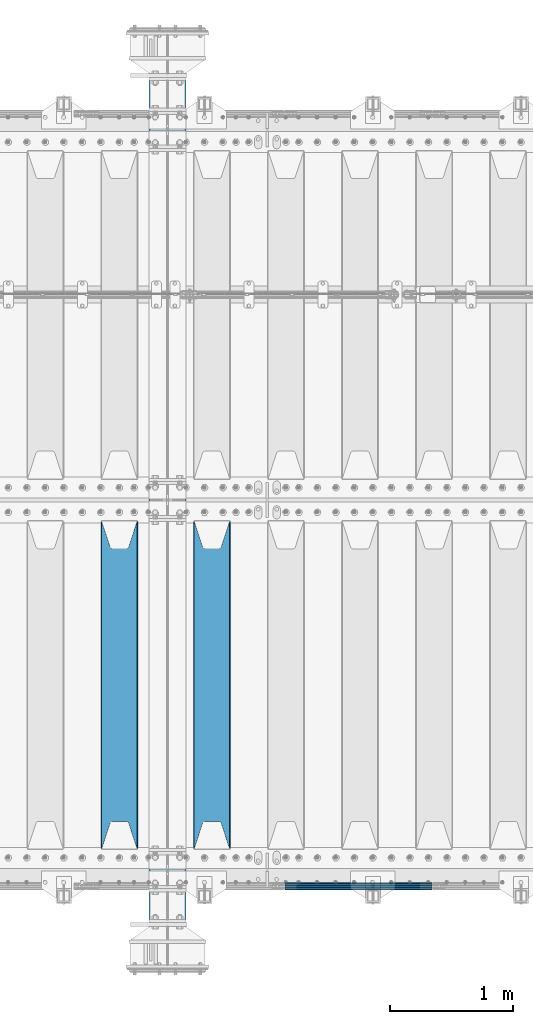
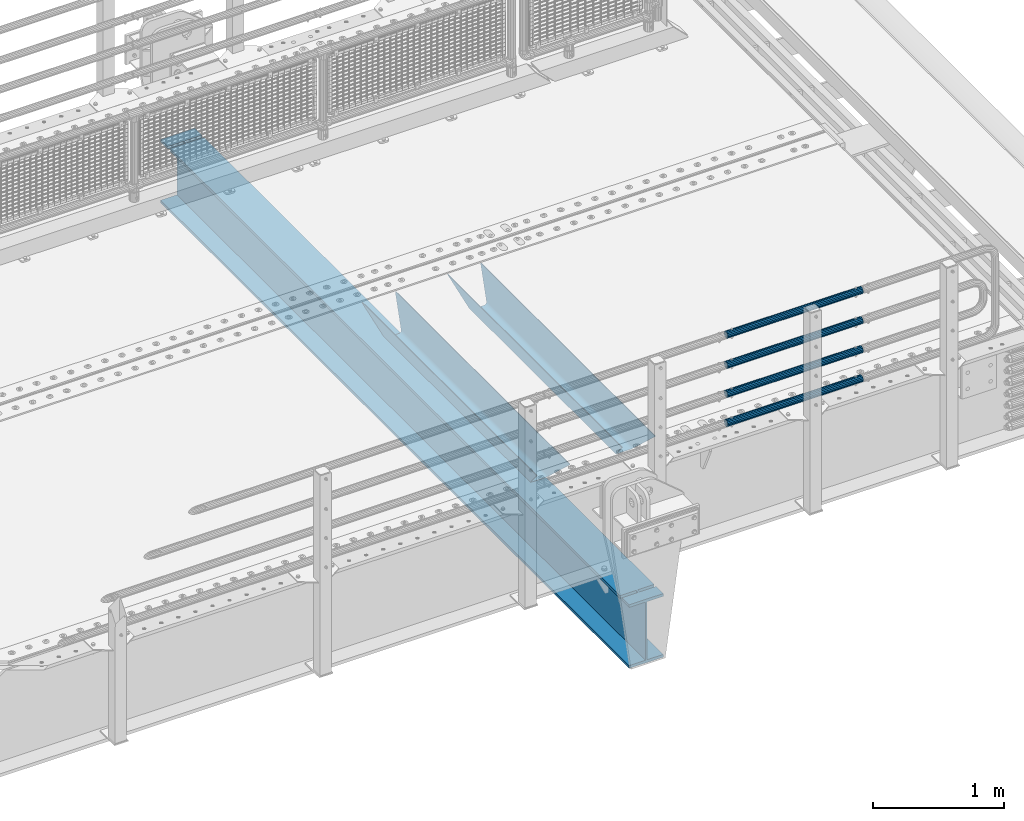
# One storey, part 95 of 193: 7 beams.
"""IFC2X3 building model written with IfcOpenShell, lengths in millimetres."""

from ifc_helpers import new_model, si_unit, frame, origin_with_axes, place, context, subcontext, project, spatial, faceted_brep, material, type_object, element, save


model = new_model("IFC2X3")

# Units and contexts
model_context = context("Model", 3, precision=1e-05, world=origin_with_axes())
body_context = subcontext(model_context, "Body", "Model", "MODEL_VIEW")
ifc_project = project(units=[si_unit("LENGTHUNIT", "METRE", prefix="MILLI"), si_unit("AREAUNIT", "SQUARE_METRE"), si_unit("VOLUMEUNIT", "CUBIC_METRE"), si_unit("MASSUNIT", "GRAM", prefix="KILO"), si_unit("TIMEUNIT", "SECOND"), si_unit("PLANEANGLEUNIT", "RADIAN"), si_unit("SOLIDANGLEUNIT", "STERADIAN"), si_unit("THERMODYNAMICTEMPERATUREUNIT", "DEGREE_CELSIUS"), si_unit("LUMINOUSINTENSITYUNIT", "LUMEN")], contexts=[model_context])

# Site, building, storey
site_placement = place(None, origin_with_axes())
site = spatial("IfcSite", under=ifc_project, at=site_placement, CompositionType="ELEMENT")
building_placement = place(site_placement, origin_with_axes())
building = spatial("IfcBuilding", under=site, at=building_placement, Name="Standard", CompositionType="ELEMENT")
storey_placement = place(building_placement, origin_with_axes())
storey = spatial("IfcBuildingStorey", under=building, at=storey_placement, Name="Undefined", CompositionType="ELEMENT", Elevation=0.0)

# Beams
ifc_material_1 = material(Name="STEEL/S355N")
beam_type_1 = type_object("IfcBeamType", PredefinedType="NOTDEFINED")
beam_1_placement = place(storey_placement, frame((-31700.0, 24175.0, -115.0), z_axis=(0.0, 0.0, 1.0), x_axis=(0.0, 1.0, 0.0)))
element("IfcBeam", 1, at=beam_1_placement, inside=storey, type_object=beam_type_1, material=ifc_material_1, context=body_context, shape_type="Brep", body=[
    faceted_brep([(0.0, 150.0, 115.0), (0.0, 143.689999999999, 115.0), (2650.00000000297, 143.689999999999, 115.0), (2650.00000000297, 150.0, 115.0), (2650.00000000297, 142.059565218398, 110.000000003094), (2650.00000000297, 148.3695652184, 110.000000003094), (2441.90079219209, -80.1103600731112, -98.0992078077845), (2437.7588105432, -77.5672621345584, -102.241189456673), (2434.06523489747, -74.4080125315522, -105.934765102404), (2430.9108609509, -70.710272125576, -109.089139048974), (2428.37322971128, -66.5649389910068, -111.626770288588), (2426.51472138055, -62.0739139532889, -113.485278619323), (2425.38102192092, -57.3475956567672, -114.618978078955), (2424.99999999988, -52.5021667386536, -115.0), (2424.99999999988, 52.5021667386536, -115.0), (2425.38102192092, 57.3475956567672, -114.618978078955), (2426.51472138055, 62.0739139532889, -113.485278619323), (2428.37322971128, 66.5649389910068, -111.626770288588), (2430.9108609509, 70.710272125576, -109.089139048974), (2434.06523489747, 74.4080125315522, -105.934765102404), (2437.7588105432, 77.5672621345584, -102.241189456673), (2441.90079219209, 80.1103600731112, -98.0992078077846), (2446.38936140512, 81.9747917625791, -93.6106385947584), (2448.2494850041, 76.2713538057251, -91.7505149957729), (2444.62967112263, 74.76777986261, -95.3703288772456), (2441.28936334127, 72.7168944282894, -98.710636658607), (2438.31067330439, 70.1691124903846, -101.689326695487), (2435.76682334748, 67.1870637758839, -104.233176652398), (2433.72034654134, 63.8440531834895, -106.279653458539), (2432.22154950042, 60.222258798236, -107.778450499454), (2431.30727574265, 56.4107117849089, -108.692724257221), (2430.99999999987, 52.5031078186876, -109.0), (2430.99999999987, -52.5031078186876, -109.0), (2431.30727574265, -56.4107117849089, -108.692724257221), (2432.22154950042, -60.222258798236, -107.778450499454), (2433.72034654134, -63.8440531834895, -106.279653458539), (2435.76682334748, -67.1870637758839, -104.233176652398), (2438.31067330439, -70.1691124903846, -101.689326695487), (2441.28936334127, -72.7168944282894, -98.7106366586071), (2444.62967112263, -74.76777986261, -95.3703288772457), (2448.2494850041, -76.2713538057251, -91.7505149957729), (2650.00000000297, -142.059565218398, 110.000000003094), (2650.00000000297, -148.3695652184, 110.000000003094), (2446.38936140512, -81.9747917625791, -93.6106385947584), (2650.00000000297, -143.689999999999, 115.0), (2650.00000000297, -150.0, 115.0), (0.0, -143.689999999999, 115.0), (0.0, -150.0, 115.0), (0.0, -148.369565218261, 110.000000002667), (203.610638597427, -81.9747917625791, -93.6106385947584), (208.099207810446, -80.1103600731112, -98.0992078077845), (212.241189459342, -77.5672621345584, -102.241189456673), (215.93476510507, -74.4080125315522, -105.934765102404), (219.089139051641, -70.710272125576, -109.089139048974), (221.626770291256, -66.5649389910068, -111.626770288588), (223.485278621989, -62.0739139532889, -113.485278619323), (224.618978081624, -57.3475956567672, -114.618978078955), (225.000000002663, -52.5021667386536, -115.0), (225.000000002663, 52.5021667386536, -115.0), (224.618978081624, 57.3475956567672, -114.618978078955), (223.485278621989, 62.0739139532889, -113.485278619323), (221.626770291256, 66.5649389910068, -111.626770288588), (219.089139051641, 70.710272125576, -109.089139048974), (215.93476510507, 74.4080125315522, -105.934765102404), (212.241189459342, 77.5672621345584, -102.241189456673), (208.099207810446, 80.1103600731112, -98.0992078077846), (203.610638597427, 81.9747917625791, -93.6106385947584), (0.0, 148.369565218261, 110.000000002667), (0.0, 142.05956521826, 110.000000002667), (201.750514998439, 76.2713538057251, -91.7505149957729), (205.370328879915, 74.76777986261, -95.3703288772456), (208.710636661275, 72.7168944282894, -98.710636658607), (211.689326698157, 70.1691124903846, -101.689326695487), (214.233176655063, 67.1870637758839, -104.233176652398), (216.279653461206, 63.8440531834895, -106.279653458539), (217.778450502123, 60.222258798236, -107.778450499454), (218.69272425989, 56.4107117849089, -108.692724257221), (219.00000000267, 52.5031078186876, -109.0), (219.00000000267, -52.5031078186876, -109.0), (218.69272425989, -56.4107117849089, -108.692724257221), (217.778450502123, -60.222258798236, -107.778450499454), (216.279653461206, -63.8440531834895, -106.279653458539), (214.233176655063, -67.1870637758839, -104.233176652398), (211.689326698157, -70.1691124903846, -101.689326695487), (208.710636661275, -72.7168944282894, -98.7106366586071), (205.370328879915, -74.76777986261, -95.3703288772457), (201.750514998439, -76.2713538057251, -91.7505149957729), (0.0, -142.05956521826, 110.000000002667)], [[[0, 1, 2, 3]], [[3, 2, 4, 5]], [[6, 7, 8, 9, 10, 11, 12, 13, 14, 15, 16, 17, 18, 19, 20, 21, 22, 5, 4, 23, 24, 25, 26, 27, 28, 29, 30, 31, 32, 33, 34, 35, 36, 37, 38, 39, 40, 41, 42, 43]], [[44, 45, 42, 41]], [[46, 47, 45, 44]], [[43, 42, 45, 47, 48, 49]], [[6, 43, 49, 50]], [[7, 6, 50, 51]], [[8, 7, 51, 52]], [[9, 8, 52, 53]], [[10, 9, 53, 54]], [[11, 10, 54, 55]], [[12, 11, 55, 56]], [[13, 12, 56, 57]], [[14, 13, 57, 58]], [[15, 14, 58, 59]], [[16, 15, 59, 60]], [[17, 16, 60, 61]], [[18, 17, 61, 62]], [[19, 18, 62, 63]], [[20, 19, 63, 64]], [[21, 20, 64, 65]], [[22, 21, 65, 66]], [[0, 3, 5, 22, 66, 67]], [[1, 0, 67, 68]], [[23, 4, 2, 1, 68, 69]], [[24, 23, 69, 70]], [[25, 24, 70, 71]], [[26, 25, 71, 72]], [[27, 26, 72, 73]], [[28, 27, 73, 74]], [[29, 28, 74, 75]], [[30, 29, 75, 76]], [[31, 30, 76, 77]], [[32, 31, 77, 78]], [[33, 32, 78, 79]], [[34, 33, 79, 80]], [[35, 34, 80, 81]], [[36, 35, 81, 82]], [[37, 36, 82, 83]], [[38, 37, 83, 84]], [[39, 38, 84, 85]], [[40, 39, 85, 86]], [[46, 44, 41, 40, 86, 87]], [[47, 46, 87, 48]], [[86, 85, 84, 83, 82, 81, 80, 79, 78, 77, 76, 75, 74, 73, 72, 71, 70, 69, 68, 67, 66, 65, 64, 63, 62, 61, 60, 59, 58, 57, 56, 55, 54, 53, 52, 51, 50, 49, 48, 87]]]),
])
beam_2_placement = place(storey_placement, frame((-32450.0, 24175.0, -115.0), z_axis=(0.0, 0.0, 1.0), x_axis=(0.0, 1.0, 0.0)))
element("IfcBeam", 2, at=beam_2_placement, inside=storey, type_object=beam_type_1, material=ifc_material_1, context=body_context, shape_type="Brep", body=[
    faceted_brep([(0.0, 150.0, 115.0), (0.0, 143.689999999999, 115.0), (2650.00000000297, 143.689999999999, 115.0), (2650.00000000297, 150.0, 115.0), (2650.00000000297, 142.059565218398, 110.000000003094), (2650.00000000297, 148.3695652184, 110.000000003094), (2441.90079219209, -80.1103600731112, -98.0992078077845), (2437.7588105432, -77.5672621345584, -102.241189456673), (2434.06523489747, -74.4080125315522, -105.934765102404), (2430.9108609509, -70.710272125576, -109.089139048974), (2428.37322971128, -66.5649389910068, -111.626770288588), (2426.51472138055, -62.0739139532889, -113.485278619323), (2425.38102192092, -57.3475956567672, -114.618978078955), (2424.99999999988, -52.5021667386536, -115.0), (2424.99999999988, 52.5021667386536, -115.0), (2425.38102192092, 57.3475956567672, -114.618978078955), (2426.51472138055, 62.0739139532889, -113.485278619323), (2428.37322971128, 66.5649389910068, -111.626770288588), (2430.9108609509, 70.710272125576, -109.089139048974), (2434.06523489747, 74.4080125315522, -105.934765102404), (2437.7588105432, 77.5672621345584, -102.241189456673), (2441.90079219209, 80.1103600731112, -98.0992078077846), (2446.38936140512, 81.9747917625791, -93.6106385947584), (2448.2494850041, 76.2713538057251, -91.7505149957729), (2444.62967112263, 74.76777986261, -95.3703288772456), (2441.28936334127, 72.7168944282894, -98.710636658607), (2438.31067330439, 70.1691124903846, -101.689326695487), (2435.76682334748, 67.1870637758839, -104.233176652398), (2433.72034654134, 63.8440531834895, -106.279653458539), (2432.22154950042, 60.222258798236, -107.778450499454), (2431.30727574265, 56.4107117849089, -108.692724257221), (2430.99999999987, 52.5031078186876, -109.0), (2430.99999999987, -52.5031078186876, -109.0), (2431.30727574265, -56.4107117849089, -108.692724257221), (2432.22154950042, -60.222258798236, -107.778450499454), (2433.72034654134, -63.8440531834895, -106.279653458539), (2435.76682334748, -67.1870637758839, -104.233176652398), (2438.31067330439, -70.1691124903846, -101.689326695487), (2441.28936334127, -72.7168944282894, -98.7106366586071), (2444.62967112263, -74.76777986261, -95.3703288772457), (2448.2494850041, -76.2713538057251, -91.7505149957729), (2650.00000000297, -142.059565218398, 110.000000003094), (2650.00000000297, -148.3695652184, 110.000000003094), (2446.38936140512, -81.9747917625791, -93.6106385947584), (2650.00000000297, -143.689999999999, 115.0), (2650.00000000297, -150.0, 115.0), (0.0, -143.689999999999, 115.0), (0.0, -150.0, 115.0), (0.0, -148.369565218261, 110.000000002667), (203.610638597427, -81.9747917625791, -93.6106385947584), (208.099207810446, -80.1103600731112, -98.0992078077845), (212.241189459342, -77.5672621345584, -102.241189456673), (215.93476510507, -74.4080125315522, -105.934765102404), (219.089139051641, -70.710272125576, -109.089139048974), (221.626770291256, -66.5649389910068, -111.626770288588), (223.485278621989, -62.0739139532889, -113.485278619323), (224.618978081624, -57.3475956567672, -114.618978078955), (225.000000002663, -52.5021667386536, -115.0), (225.000000002663, 52.5021667386536, -115.0), (224.618978081624, 57.3475956567672, -114.618978078955), (223.485278621989, 62.0739139532889, -113.485278619323), (221.626770291256, 66.5649389910068, -111.626770288588), (219.089139051641, 70.710272125576, -109.089139048974), (215.93476510507, 74.4080125315522, -105.934765102404), (212.241189459342, 77.5672621345584, -102.241189456673), (208.099207810446, 80.1103600731112, -98.0992078077846), (203.610638597427, 81.9747917625791, -93.6106385947584), (0.0, 148.369565218261, 110.000000002667), (0.0, 142.05956521826, 110.000000002667), (201.750514998439, 76.2713538057251, -91.7505149957729), (205.370328879915, 74.76777986261, -95.3703288772456), (208.710636661275, 72.7168944282894, -98.710636658607), (211.689326698157, 70.1691124903846, -101.689326695487), (214.233176655063, 67.1870637758839, -104.233176652398), (216.279653461206, 63.8440531834895, -106.279653458539), (217.778450502123, 60.222258798236, -107.778450499454), (218.69272425989, 56.4107117849089, -108.692724257221), (219.00000000267, 52.5031078186876, -109.0), (219.00000000267, -52.5031078186876, -109.0), (218.69272425989, -56.4107117849089, -108.692724257221), (217.778450502123, -60.222258798236, -107.778450499454), (216.279653461206, -63.8440531834895, -106.279653458539), (214.233176655063, -67.1870637758839, -104.233176652398), (211.689326698157, -70.1691124903846, -101.689326695487), (208.710636661275, -72.7168944282894, -98.7106366586071), (205.370328879915, -74.76777986261, -95.3703288772457), (201.750514998439, -76.2713538057251, -91.7505149957729), (0.0, -142.05956521826, 110.000000002667)], [[[0, 1, 2, 3]], [[3, 2, 4, 5]], [[6, 7, 8, 9, 10, 11, 12, 13, 14, 15, 16, 17, 18, 19, 20, 21, 22, 5, 4, 23, 24, 25, 26, 27, 28, 29, 30, 31, 32, 33, 34, 35, 36, 37, 38, 39, 40, 41, 42, 43]], [[44, 45, 42, 41]], [[46, 47, 45, 44]], [[43, 42, 45, 47, 48, 49]], [[6, 43, 49, 50]], [[7, 6, 50, 51]], [[8, 7, 51, 52]], [[9, 8, 52, 53]], [[10, 9, 53, 54]], [[11, 10, 54, 55]], [[12, 11, 55, 56]], [[13, 12, 56, 57]], [[14, 13, 57, 58]], [[15, 14, 58, 59]], [[16, 15, 59, 60]], [[17, 16, 60, 61]], [[18, 17, 61, 62]], [[19, 18, 62, 63]], [[20, 19, 63, 64]], [[21, 20, 64, 65]], [[22, 21, 65, 66]], [[0, 3, 5, 22, 66, 67]], [[1, 0, 67, 68]], [[23, 4, 2, 1, 68, 69]], [[24, 23, 69, 70]], [[25, 24, 70, 71]], [[26, 25, 71, 72]], [[27, 26, 72, 73]], [[28, 27, 73, 74]], [[29, 28, 74, 75]], [[30, 29, 75, 76]], [[31, 30, 76, 77]], [[32, 31, 77, 78]], [[33, 32, 78, 79]], [[34, 33, 79, 80]], [[35, 34, 80, 81]], [[36, 35, 81, 82]], [[37, 36, 82, 83]], [[38, 37, 83, 84]], [[39, 38, 84, 85]], [[40, 39, 85, 86]], [[46, 44, 41, 40, 86, 87]], [[47, 46, 87, 48]], [[86, 85, 84, 83, 82, 81, 80, 79, 78, 77, 76, 75, 74, 73, 72, 71, 70, 69, 68, 67, 66, 65, 64, 63, 62, 61, 60, 59, 58, 57, 56, 55, 54, 53, 52, 51, 50, 49, 48, 87]]]),
])
ifc_material_2 = material()
beam_type_2 = type_object("IfcBeamType", PredefinedType="NOTDEFINED")
beam_3_placement = place(storey_placement, frame((-31107.9999999999, 23870.1499999996, 419.849999999748), z_axis=(0.0, -1.0, 0.0), x_axis=(1.0, 0.0, 0.0)))
element("IfcBeam", 3, at=beam_3_placement, inside=storey, type_object=beam_type_2, material=ifc_material_2, context=body_context, shape_type="Brep", body=[
    faceted_brep([(0.0, -26.5499999999993, 0.0), (0.0, -24.5290015881765, 10.1602451292931), (1190.0, -24.5290015881747, 10.1602451292929), (1190.0, -26.55, 0.0), (0.0, -18.7736850405017, 18.7736850405028), (1190.0, -18.7736850405028, 18.7736850405017), (0.0, -10.1602451292929, 24.5290015881747), (1190.0, -10.1602451292931, 24.5290015881765), (0.0, 0.0, 26.55), (1190.0, 0.0, 26.5499999999993), (0.0, 10.1602451292929, 24.5290015881747), (1190.0, 10.1602451292932, 24.5290015881765), (0.0, 18.7736850405017, 18.7736850405028), (1190.0, 18.7736850405029, 18.7736850405017), (0.0, 24.5290015881765, 10.1602451292931), (1190.0, 24.5290015881747, 10.1602451292929), (0.0, 26.5499999999993, 0.0), (1190.0, 26.55, 0.0), (0.0, 24.5290015881765, -10.1602451292931), (1190.0, 24.5290015881747, -10.1602451292929), (0.0, 18.7736850405017, -18.7736850405028), (1190.0, 18.7736850405028, -18.7736850405017), (0.0, 10.1602451292929, -24.5290015881747), (1190.0, 10.1602451292931, -24.5290015881765), (0.0, 0.0, -26.55), (1190.0, 0.0, -26.5499999999993), (0.0, -10.1602451292929, -24.5290015881747), (1190.0, -10.1602451292931, -24.5290015881765), (0.0, -18.7736850405017, -18.7736850405028), (1190.0, -18.7736850405028, -18.7736850405017), (0.0, -24.5290015881765, -10.1602451292931), (1190.0, -24.5290015881747, -10.1602451292929), (0.0, -30.1500000000015, 0.0), (0.0, -27.8549679052157, -11.5379054858058), (1190.0, -27.8549679052153, -11.5379054858058), (1190.0, -30.15, 0.0), (0.0, -21.3192694527752, -21.3192694527752), (1190.0, -21.3192694527744, -21.3192694527752), (0.0, -11.5379054858058, -27.8549679052157), (1190.0, -11.5379054858075, -27.8549679052157), (0.0, 0.0, -30.1500000000015), (1190.0, 0.0, -30.1500000000015), (0.0, 11.5379054858058, -27.8549679052157), (1190.0, 11.5379054858075, -27.8549679052157), (0.0, 21.3192694527752, -21.3192694527752), (1190.0, 21.3192694527744, -21.3192694527752), (0.0, 27.8549679052157, -11.5379054858058), (1190.0, 27.8549679052153, -11.5379054858058), (0.0, 30.1500000000015, 0.0), (1190.0, 30.15, 0.0), (0.0, 27.8549679052157, 11.5379054858058), (1190.0, 27.8549679052153, 11.5379054858058), (0.0, 21.3192694527752, 21.3192694527752), (1190.0, 21.3192694527744, 21.3192694527752), (0.0, 11.5379054858058, 27.8549679052157), (1190.0, 11.5379054858075, 27.8549679052157), (0.0, 0.0, 30.1500000000015), (1190.0, 0.0, 30.1500000000015), (0.0, -11.5379054858058, 27.8549679052157), (1190.0, -11.5379054858075, 27.8549679052157), (0.0, -21.3192694527752, 21.3192694527752), (1190.0, -21.3192694527744, 21.3192694527752), (0.0, -27.8549679052157, 11.5379054858058), (1190.0, -27.8549679052153, 11.5379054858058)], [[[0, 1, 2, 3]], [[1, 4, 5, 2]], [[4, 6, 7, 5]], [[6, 8, 9, 7]], [[8, 10, 11, 9]], [[10, 12, 13, 11]], [[12, 14, 15, 13]], [[14, 16, 17, 15]], [[16, 18, 19, 17]], [[18, 20, 21, 19]], [[20, 22, 23, 21]], [[22, 24, 25, 23]], [[24, 26, 27, 25]], [[26, 28, 29, 27]], [[28, 30, 31, 29]], [[30, 0, 3, 31]], [[32, 33, 34, 35]], [[33, 36, 37, 34]], [[36, 38, 39, 37]], [[38, 40, 41, 39]], [[40, 42, 43, 41]], [[42, 44, 45, 43]], [[44, 46, 47, 45]], [[46, 48, 49, 47]], [[48, 50, 51, 49]], [[50, 52, 53, 51]], [[52, 54, 55, 53]], [[54, 56, 57, 55]], [[56, 58, 59, 57]], [[58, 60, 61, 59]], [[60, 62, 63, 61]], [[62, 32, 35, 63]], [[37, 39, 41, 43, 45, 47, 49, 51, 53, 55, 57, 59, 61, 63, 35, 34], [5, 7, 9, 11, 13, 15, 17, 19, 21, 23, 25, 27, 29, 31, 3, 2]], [[62, 60, 58, 56, 54, 52, 50, 48, 46, 44, 42, 40, 38, 36, 33, 32], [30, 28, 26, 24, 22, 20, 18, 16, 14, 12, 10, 8, 6, 4, 1, 0]]]),
])
beam_4_placement = place(storey_placement, frame((-31107.9999999999, 23870.1499999996, 149.549999999748), z_axis=(0.0, -1.0, 0.0), x_axis=(1.0, 0.0, 0.0)))
element("IfcBeam", 4, at=beam_4_placement, inside=storey, type_object=beam_type_2, material=ifc_material_2, context=body_context, shape_type="Brep", body=[
    faceted_brep([(0.0, -26.5499999999993, 0.0), (0.0, -24.5290015881765, 10.1602451292931), (1190.0, -24.5290015881747, 10.1602451292929), (1190.0, -26.55, 0.0), (0.0, -18.7736850405017, 18.7736850405028), (1190.0, -18.7736850405028, 18.7736850405017), (0.0, -10.1602451292929, 24.5290015881747), (1190.0, -10.1602451292931, 24.5290015881765), (0.0, 0.0, 26.55), (1190.0, 0.0, 26.5499999999993), (0.0, 10.1602451292929, 24.5290015881747), (1190.0, 10.1602451292932, 24.5290015881765), (0.0, 18.7736850405017, 18.7736850405028), (1190.0, 18.7736850405029, 18.7736850405017), (0.0, 24.5290015881765, 10.1602451292931), (1190.0, 24.5290015881747, 10.1602451292929), (0.0, 26.5499999999993, 0.0), (1190.0, 26.55, 0.0), (0.0, 24.5290015881765, -10.1602451292931), (1190.0, 24.5290015881747, -10.1602451292929), (0.0, 18.7736850405017, -18.7736850405028), (1190.0, 18.7736850405028, -18.7736850405017), (0.0, 10.1602451292929, -24.5290015881747), (1190.0, 10.1602451292931, -24.5290015881765), (0.0, 0.0, -26.55), (1190.0, 0.0, -26.5499999999993), (0.0, -10.1602451292929, -24.5290015881747), (1190.0, -10.1602451292931, -24.5290015881765), (0.0, -18.7736850405017, -18.7736850405028), (1190.0, -18.7736850405028, -18.7736850405017), (0.0, -24.5290015881765, -10.1602451292931), (1190.0, -24.5290015881747, -10.1602451292929), (0.0, -30.1500000000015, 0.0), (0.0, -27.8549679052157, -11.5379054858058), (1190.0, -27.8549679052153, -11.5379054858058), (1190.0, -30.15, 0.0), (0.0, -21.3192694527752, -21.3192694527752), (1190.0, -21.3192694527744, -21.3192694527752), (0.0, -11.5379054858058, -27.8549679052157), (1190.0, -11.5379054858075, -27.8549679052157), (0.0, 0.0, -30.1500000000015), (1190.0, 0.0, -30.1500000000015), (0.0, 11.5379054858058, -27.8549679052157), (1190.0, 11.5379054858075, -27.8549679052157), (0.0, 21.3192694527752, -21.3192694527752), (1190.0, 21.3192694527744, -21.3192694527752), (0.0, 27.8549679052157, -11.5379054858058), (1190.0, 27.8549679052153, -11.5379054858058), (0.0, 30.1500000000015, 0.0), (1190.0, 30.15, 0.0), (0.0, 27.8549679052157, 11.5379054858058), (1190.0, 27.8549679052153, 11.5379054858058), (0.0, 21.3192694527752, 21.3192694527752), (1190.0, 21.3192694527744, 21.3192694527752), (0.0, 11.5379054858058, 27.8549679052157), (1190.0, 11.5379054858075, 27.8549679052157), (0.0, 0.0, 30.1500000000015), (1190.0, 0.0, 30.1500000000015), (0.0, -11.5379054858058, 27.8549679052157), (1190.0, -11.5379054858075, 27.8549679052157), (0.0, -21.3192694527752, 21.3192694527752), (1190.0, -21.3192694527744, 21.3192694527752), (0.0, -27.8549679052157, 11.5379054858058), (1190.0, -27.8549679052153, 11.5379054858058)], [[[0, 1, 2, 3]], [[1, 4, 5, 2]], [[4, 6, 7, 5]], [[6, 8, 9, 7]], [[8, 10, 11, 9]], [[10, 12, 13, 11]], [[12, 14, 15, 13]], [[14, 16, 17, 15]], [[16, 18, 19, 17]], [[18, 20, 21, 19]], [[20, 22, 23, 21]], [[22, 24, 25, 23]], [[24, 26, 27, 25]], [[26, 28, 29, 27]], [[28, 30, 31, 29]], [[30, 0, 3, 31]], [[32, 33, 34, 35]], [[33, 36, 37, 34]], [[36, 38, 39, 37]], [[38, 40, 41, 39]], [[40, 42, 43, 41]], [[42, 44, 45, 43]], [[44, 46, 47, 45]], [[46, 48, 49, 47]], [[48, 50, 51, 49]], [[50, 52, 53, 51]], [[52, 54, 55, 53]], [[54, 56, 57, 55]], [[56, 58, 59, 57]], [[58, 60, 61, 59]], [[60, 62, 63, 61]], [[62, 32, 35, 63]], [[37, 39, 41, 43, 45, 47, 49, 51, 53, 55, 57, 59, 61, 63, 35, 34], [5, 7, 9, 11, 13, 15, 17, 19, 21, 23, 25, 27, 29, 31, 3, 2]], [[62, 60, 58, 56, 54, 52, 50, 48, 46, 44, 42, 40, 38, 36, 33, 32], [30, 28, 26, 24, 22, 20, 18, 16, 14, 12, 10, 8, 6, 4, 1, 0]]]),
])
beam_5_placement = place(storey_placement, frame((-31107.9999999999, 23870.1499999996, 969.549999999748), z_axis=(0.0, -1.0, 0.0), x_axis=(1.0, 0.0, 0.0)))
element("IfcBeam", 5, at=beam_5_placement, inside=storey, type_object=beam_type_2, material=ifc_material_2, context=body_context, shape_type="Brep", body=[
    faceted_brep([(0.0, -26.5499999999993, 0.0), (0.0, -24.5290015881765, 10.1602451292931), (1190.0, -24.5290015881747, 10.1602451292929), (1190.0, -26.55, 0.0), (0.0, -18.7736850405017, 18.7736850405028), (1190.0, -18.7736850405028, 18.7736850405017), (0.0, -10.1602451292929, 24.5290015881747), (1190.0, -10.1602451292931, 24.5290015881765), (0.0, 0.0, 26.55), (1190.0, 0.0, 26.5499999999993), (0.0, 10.1602451292929, 24.5290015881747), (1190.0, 10.1602451292932, 24.5290015881765), (0.0, 18.7736850405017, 18.7736850405028), (1190.0, 18.7736850405029, 18.7736850405017), (0.0, 24.5290015881765, 10.1602451292931), (1190.0, 24.5290015881747, 10.1602451292929), (0.0, 26.5499999999993, 0.0), (1190.0, 26.55, 0.0), (0.0, 24.5290015881765, -10.1602451292931), (1190.0, 24.5290015881747, -10.1602451292929), (0.0, 18.7736850405017, -18.7736850405028), (1190.0, 18.7736850405028, -18.7736850405017), (0.0, 10.1602451292929, -24.5290015881747), (1190.0, 10.1602451292931, -24.5290015881765), (0.0, 0.0, -26.55), (1190.0, 0.0, -26.5499999999993), (0.0, -10.1602451292929, -24.5290015881747), (1190.0, -10.1602451292931, -24.5290015881765), (0.0, -18.7736850405017, -18.7736850405028), (1190.0, -18.7736850405028, -18.7736850405017), (0.0, -24.5290015881765, -10.1602451292931), (1190.0, -24.5290015881747, -10.1602451292929), (0.0, -30.1500000000015, 0.0), (0.0, -27.8549679052157, -11.5379054858058), (1190.0, -27.8549679052153, -11.5379054858058), (1190.0, -30.15, 0.0), (0.0, -21.3192694527752, -21.3192694527752), (1190.0, -21.3192694527744, -21.3192694527752), (0.0, -11.5379054858058, -27.8549679052157), (1190.0, -11.5379054858075, -27.8549679052157), (0.0, 0.0, -30.1500000000015), (1190.0, 0.0, -30.1500000000015), (0.0, 11.5379054858058, -27.8549679052157), (1190.0, 11.5379054858075, -27.8549679052157), (0.0, 21.3192694527752, -21.3192694527752), (1190.0, 21.3192694527744, -21.3192694527752), (0.0, 27.8549679052157, -11.5379054858058), (1190.0, 27.8549679052153, -11.5379054858058), (0.0, 30.1500000000015, 0.0), (1190.0, 30.15, 0.0), (0.0, 27.8549679052157, 11.5379054858058), (1190.0, 27.8549679052153, 11.5379054858058), (0.0, 21.3192694527752, 21.3192694527752), (1190.0, 21.3192694527744, 21.3192694527752), (0.0, 11.5379054858058, 27.8549679052157), (1190.0, 11.5379054858075, 27.8549679052157), (0.0, 0.0, 30.1500000000015), (1190.0, 0.0, 30.1500000000015), (0.0, -11.5379054858058, 27.8549679052157), (1190.0, -11.5379054858075, 27.8549679052157), (0.0, -21.3192694527752, 21.3192694527752), (1190.0, -21.3192694527744, 21.3192694527752), (0.0, -27.8549679052157, 11.5379054858058), (1190.0, -27.8549679052153, 11.5379054858058)], [[[0, 1, 2, 3]], [[1, 4, 5, 2]], [[4, 6, 7, 5]], [[6, 8, 9, 7]], [[8, 10, 11, 9]], [[10, 12, 13, 11]], [[12, 14, 15, 13]], [[14, 16, 17, 15]], [[16, 18, 19, 17]], [[18, 20, 21, 19]], [[20, 22, 23, 21]], [[22, 24, 25, 23]], [[24, 26, 27, 25]], [[26, 28, 29, 27]], [[28, 30, 31, 29]], [[30, 0, 3, 31]], [[32, 33, 34, 35]], [[33, 36, 37, 34]], [[36, 38, 39, 37]], [[38, 40, 41, 39]], [[40, 42, 43, 41]], [[42, 44, 45, 43]], [[44, 46, 47, 45]], [[46, 48, 49, 47]], [[48, 50, 51, 49]], [[50, 52, 53, 51]], [[52, 54, 55, 53]], [[54, 56, 57, 55]], [[56, 58, 59, 57]], [[58, 60, 61, 59]], [[60, 62, 63, 61]], [[62, 32, 35, 63]], [[37, 39, 41, 43, 45, 47, 49, 51, 53, 55, 57, 59, 61, 63, 35, 34], [5, 7, 9, 11, 13, 15, 17, 19, 21, 23, 25, 27, 29, 31, 3, 2]], [[62, 60, 58, 56, 54, 52, 50, 48, 46, 44, 42, 40, 38, 36, 33, 32], [30, 28, 26, 24, 22, 20, 18, 16, 14, 12, 10, 8, 6, 4, 1, 0]]]),
])
beam_6_placement = place(storey_placement, frame((-31107.9999999999, 23870.1499999996, 689.549999999748), z_axis=(0.0, -1.0, 0.0), x_axis=(1.0, 0.0, 0.0)))
element("IfcBeam", 6, at=beam_6_placement, inside=storey, type_object=beam_type_2, material=ifc_material_2, context=body_context, shape_type="Brep", body=[
    faceted_brep([(0.0, -26.5499999999993, 0.0), (0.0, -24.5290015881765, 10.1602451292931), (1190.0, -24.5290015881747, 10.1602451292929), (1190.0, -26.55, 0.0), (0.0, -18.7736850405017, 18.7736850405028), (1190.0, -18.7736850405028, 18.7736850405017), (0.0, -10.1602451292929, 24.5290015881747), (1190.0, -10.1602451292931, 24.5290015881765), (0.0, 0.0, 26.55), (1190.0, 0.0, 26.5499999999993), (0.0, 10.1602451292929, 24.5290015881747), (1190.0, 10.1602451292932, 24.5290015881765), (0.0, 18.7736850405017, 18.7736850405028), (1190.0, 18.7736850405029, 18.7736850405017), (0.0, 24.5290015881765, 10.1602451292931), (1190.0, 24.5290015881747, 10.1602451292929), (0.0, 26.5499999999993, 0.0), (1190.0, 26.55, 0.0), (0.0, 24.5290015881765, -10.1602451292931), (1190.0, 24.5290015881747, -10.1602451292929), (0.0, 18.7736850405017, -18.7736850405028), (1190.0, 18.7736850405028, -18.7736850405017), (0.0, 10.1602451292929, -24.5290015881747), (1190.0, 10.1602451292931, -24.5290015881765), (0.0, 0.0, -26.55), (1190.0, 0.0, -26.5499999999993), (0.0, -10.1602451292929, -24.5290015881747), (1190.0, -10.1602451292931, -24.5290015881765), (0.0, -18.7736850405017, -18.7736850405028), (1190.0, -18.7736850405028, -18.7736850405017), (0.0, -24.5290015881765, -10.1602451292931), (1190.0, -24.5290015881747, -10.1602451292929), (0.0, -30.1500000000015, 0.0), (0.0, -27.8549679052157, -11.5379054858058), (1190.0, -27.8549679052153, -11.5379054858058), (1190.0, -30.15, 0.0), (0.0, -21.3192694527752, -21.3192694527752), (1190.0, -21.3192694527744, -21.3192694527752), (0.0, -11.5379054858058, -27.8549679052157), (1190.0, -11.5379054858075, -27.8549679052157), (0.0, 0.0, -30.1500000000015), (1190.0, 0.0, -30.1500000000015), (0.0, 11.5379054858058, -27.8549679052157), (1190.0, 11.5379054858075, -27.8549679052157), (0.0, 21.3192694527752, -21.3192694527752), (1190.0, 21.3192694527744, -21.3192694527752), (0.0, 27.8549679052157, -11.5379054858058), (1190.0, 27.8549679052153, -11.5379054858058), (0.0, 30.1500000000015, 0.0), (1190.0, 30.15, 0.0), (0.0, 27.8549679052157, 11.5379054858058), (1190.0, 27.8549679052153, 11.5379054858058), (0.0, 21.3192694527752, 21.3192694527752), (1190.0, 21.3192694527744, 21.3192694527752), (0.0, 11.5379054858058, 27.8549679052157), (1190.0, 11.5379054858075, 27.8549679052157), (0.0, 0.0, 30.1500000000015), (1190.0, 0.0, 30.1500000000015), (0.0, -11.5379054858058, 27.8549679052157), (1190.0, -11.5379054858075, 27.8549679052157), (0.0, -21.3192694527752, 21.3192694527752), (1190.0, -21.3192694527744, 21.3192694527752), (0.0, -27.8549679052157, 11.5379054858058), (1190.0, -27.8549679052153, 11.5379054858058)], [[[0, 1, 2, 3]], [[1, 4, 5, 2]], [[4, 6, 7, 5]], [[6, 8, 9, 7]], [[8, 10, 11, 9]], [[10, 12, 13, 11]], [[12, 14, 15, 13]], [[14, 16, 17, 15]], [[16, 18, 19, 17]], [[18, 20, 21, 19]], [[20, 22, 23, 21]], [[22, 24, 25, 23]], [[24, 26, 27, 25]], [[26, 28, 29, 27]], [[28, 30, 31, 29]], [[30, 0, 3, 31]], [[32, 33, 34, 35]], [[33, 36, 37, 34]], [[36, 38, 39, 37]], [[38, 40, 41, 39]], [[40, 42, 43, 41]], [[42, 44, 45, 43]], [[44, 46, 47, 45]], [[46, 48, 49, 47]], [[48, 50, 51, 49]], [[50, 52, 53, 51]], [[52, 54, 55, 53]], [[54, 56, 57, 55]], [[56, 58, 59, 57]], [[58, 60, 61, 59]], [[60, 62, 63, 61]], [[62, 32, 35, 63]], [[37, 39, 41, 43, 45, 47, 49, 51, 53, 55, 57, 59, 61, 63, 35, 34], [5, 7, 9, 11, 13, 15, 17, 19, 21, 23, 25, 27, 29, 31, 3, 2]], [[62, 60, 58, 56, 54, 52, 50, 48, 46, 44, 42, 40, 38, 36, 33, 32], [30, 28, 26, 24, 22, 20, 18, 16, 14, 12, 10, 8, 6, 4, 1, 0]]]),
])
beam_type_3 = type_object("IfcBeamType", Name="HEA600", PredefinedType="NOTDEFINED")
beam_7_placement = place(storey_placement, frame((-32060.0000002028, 23435.0000000048, -1185.00001823836), z_axis=(0.0, 0.0, 1.0), x_axis=(0.0, 1.0, 0.0)))
element("IfcBeam", 7, at=beam_7_placement, inside=storey, type_object=beam_type_3, material=ifc_material_1, ObjectType="HEA600", context=body_context, shape_type="Brep", body=[
    faceted_brep([(6989.99999999953, -150.000000005406, 295.0), (6989.99999999953, -150.0, 270.0), (6989.99999999953, -6.5, 270.0), (6989.99999999953, -6.5, 295.0), (7019.99999999953, -6.5, 270.0), (7019.99999999953, -6.5, 295.0), (7019.99999999953, -150.0, 295.0), (7019.99999999953, -150.0, 270.0), (7129.99999999953, -150.0, 270.0), (7129.99999999953, -150.0, 295.0), (7129.99999999953, -6.5, 270.0), (7129.99999999953, 150.0, 295.0), (7129.99999999953, 150.0, 270.0), (7019.99999999953, 150.0, 270.0), (7019.99999999953, 150.0, 295.0), (140.000000104912, 6.5, 270.0), (140.000000385433, 150.0, 270.0), (6989.99999999953, 150.0, 270.0), (6989.99999999953, 6.5, 270.0), (0.0, -150.0, -295.0), (0.0, 150.0, -295.0), (7129.99999999953, 150.0, -295.0), (7129.99999999953, -150.0, -295.0), (7019.99999999953, -150.0, -270.0), (6989.99999999953, -150.0, -270.0), (139.999999798882, -150.0, -270.0), (109.999999798882, -150.0, -270.0), (0.0, -150.0, -270.0), (7129.99999999953, -150.0, -270.0), (7019.99999999953, -6.5, -270.0), (6989.99999999953, -6.5, -270.0), (140.000000085718, -6.5, -270.0), (110.000000085882, -6.5, -270.0), (0.0, -6.5, -270.0), (7129.99999999953, -6.5, -270.0), (0.0, -150.0, 270.0), (0.0, -6.5, 270.0), (110.000000085882, -6.5, 270.0), (109.999999798882, -150.0, 270.0), (139.999999798882, -150.000000269996, 295.0), (140.000000085718, -6.50000026999624, 295.0), (140.000000085718, -6.5, 270.0), (139.999999798882, -150.0, 270.0), (110.000000085882, -6.50000020999505, 295.0), (109.999999798882, -150.0, 295.0), (0.0, -150.0, 295.0), (0.0, 6.5, 270.0), (0.0, 150.0, 270.0), (110.000000385433, 150.0, 270.0), (110.000000385433, 6.5, 270.0), (0.0, 150.0, 295.0), (0.0, 6.5, -270.0), (0.0, 150.0, -270.0), (110.000000385433, 150.0, 295.0), (110.000000385433, 6.49999973080412, 295.0), (140.000000104912, 6.49999973080412, 295.0), (140.000000385433, 150.0, 295.0), (6989.99999999953, 150.0, 295.0), (6989.99999999953, 6.5, 295.0), (7019.99999999953, 6.5, 295.0), (7019.99999999953, 6.5, 270.0), (7129.99999999953, 6.5, 270.0), (7019.99999999953, 6.5, -270.0), (6989.99999999953, 6.5, -270.0), (140.000000104912, 6.5, -270.0), (110.000000385433, 6.5, -270.0), (7129.99999999953, 6.5, -270.0), (7019.99999999953, 150.0, -270.0), (6989.99999999953, 150.0, -270.0), (140.000000385433, 150.0, -270.0), (110.000000385433, 150.0, -270.0), (7129.99999999953, 150.0, -270.0)], [[[0, 1, 2, 3]], [[3, 2, 4, 5]], [[6, 5, 4, 7]], [[8, 9, 6, 7]], [[10, 8, 7, 4]], [[11, 12, 13, 14]], [[15, 16, 17, 18]], [[19, 20, 21, 22]], [[23, 24, 25, 26, 27, 19, 22, 28]], [[29, 30, 31, 32, 33, 27, 26, 25, 24, 23, 28, 34]], [[35, 36, 37, 38]], [[39, 40, 41, 42]], [[43, 37, 41, 40]], [[44, 38, 37, 43]], [[45, 35, 38, 44]], [[46, 47, 48, 49]], [[19, 27, 33, 36, 35, 45, 50, 47, 46, 51, 52, 20]], [[47, 50, 53, 48]], [[54, 49, 48, 53]], [[55, 15, 49, 54]], [[56, 16, 15, 55]], [[16, 56, 57, 17]], [[58, 18, 17, 57]], [[59, 60, 18, 58]], [[14, 13, 60, 59]], [[12, 61, 60, 13]], [[62, 63, 64, 65, 51, 46, 49, 15, 18, 60, 61, 66]], [[67, 68, 69, 70, 52, 51, 65, 64, 63, 62, 66, 71]], [[20, 52, 70, 69, 68, 67, 71, 21]], [[66, 61, 12, 11, 9, 8, 10, 34, 28, 22, 21, 71]], [[4, 2, 41, 37, 36, 33, 32, 31, 30, 29, 34, 10]], [[42, 41, 2, 1]], [[39, 42, 1, 0]], [[9, 11, 14, 59, 58, 57, 56, 55, 54, 53, 50, 45, 44, 43, 40, 39, 0, 3, 5, 6]]]),
])

save(model, "model.ifc")
